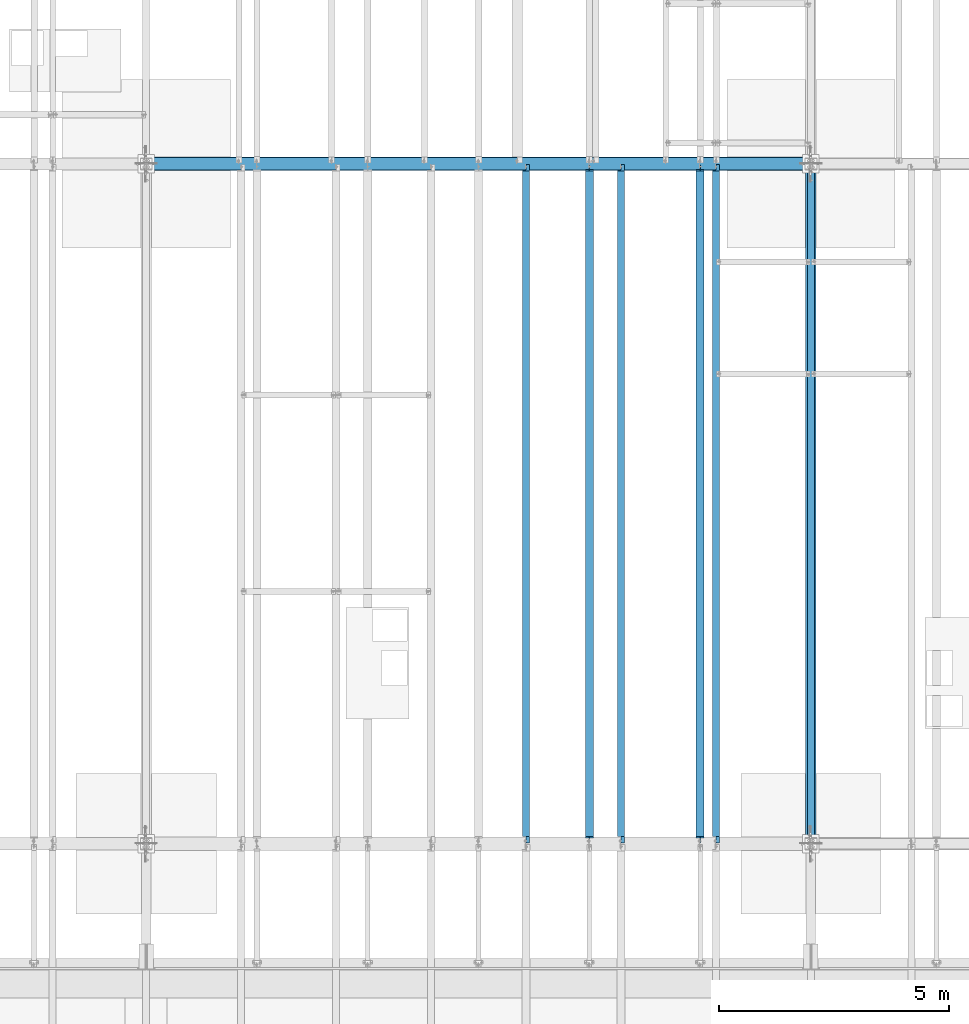
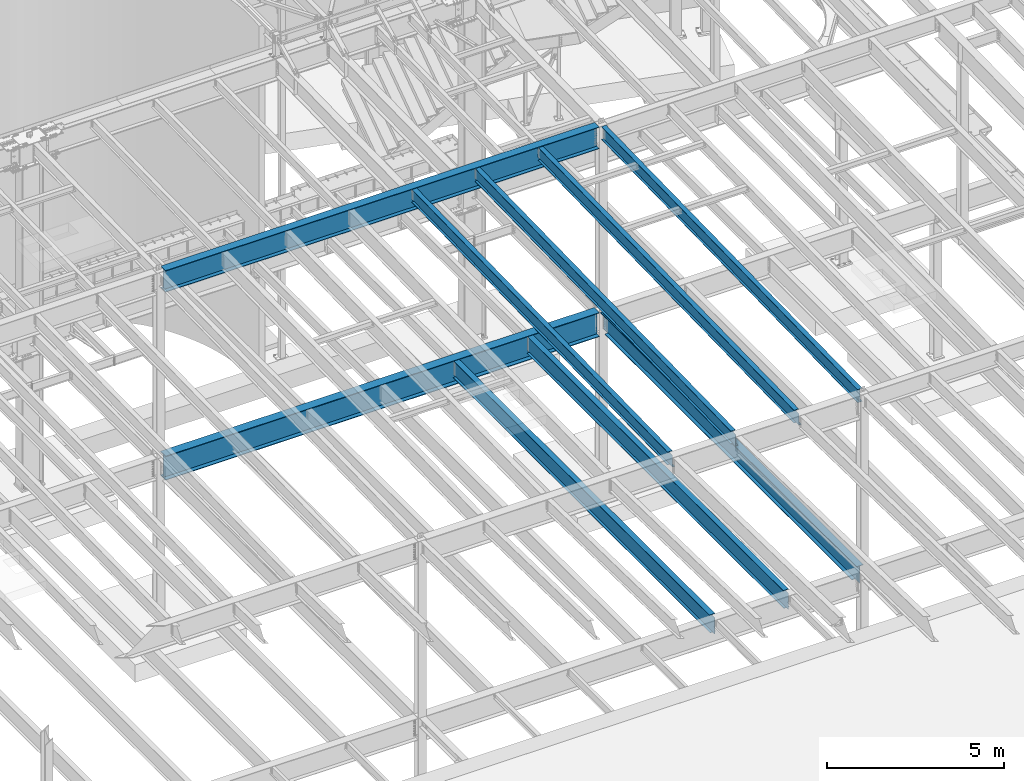
# One storey, part 1108 of 1763: 9 beams, 9 elements without a shape of their own.
"""IFC2X3 building model written with IfcOpenShell, lengths in millimetres."""

from ifc_helpers import new_model, si_unit, frame, origin_with_axes, place, context, subcontext, project, spatial, faceted_brep, material, type_object, element, aggregate, save


model = new_model("IFC2X3")

# Units and contexts
model_context = context("Model", 3, precision=1e-05, world=origin_with_axes())
body_context = subcontext(model_context, "Body", "Model", "MODEL_VIEW")
ifc_project = project(units=[si_unit("LENGTHUNIT", "METRE", prefix="MILLI"), si_unit("AREAUNIT", "SQUARE_METRE"), si_unit("VOLUMEUNIT", "CUBIC_METRE"), si_unit("MASSUNIT", "GRAM", prefix="KILO"), si_unit("TIMEUNIT", "SECOND"), si_unit("PLANEANGLEUNIT", "RADIAN"), si_unit("SOLIDANGLEUNIT", "STERADIAN"), si_unit("THERMODYNAMICTEMPERATUREUNIT", "DEGREE_CELSIUS"), si_unit("LUMINOUSINTENSITYUNIT", "LUMEN")], contexts=[model_context])

# Site, building, storey
site_placement = place(None, origin_with_axes())
site = spatial("IfcSite", under=ifc_project, at=site_placement, CompositionType="ELEMENT")
building_placement = place(site_placement, origin_with_axes())
building = spatial("IfcBuilding", under=site, at=building_placement, Name="Undefined", CompositionType="ELEMENT")
storey_placement = place(building_placement, origin_with_axes())
storey = spatial("IfcBuildingStorey", under=building, at=storey_placement, Name="Undefined", CompositionType="ELEMENT", Elevation=0.0)

# Assembly, beam
assembly_1_placement = place(storey_placement, origin_with_axes())
assembly_1 = element("IfcElementAssembly", 1, at=assembly_1_placement, inside=storey, Name="BEAM", AssemblyPlace="NOTDEFINED", PredefinedType="RIGID_FRAME")
ifc_material = material(Name="STEEL/A992")
beam_type_1 = type_object("IfcBeamType", Name="W18X35", PredefinedType="NOTDEFINED")
beam_1_placement = place(assembly_1_placement, frame((-37014.4944165555, 30027.4629676774, 11064.9232324289), z_axis=(0.0, -0.0206852279954837, 0.999786037781472), x_axis=(0.0, 0.999786037781472, 0.0206852279954825)))
beam_1 = element("IfcBeam", 2, at=beam_1_placement, type_object=beam_type_1, material=ifc_material, Name="BEAM", ObjectType="W18X35", context=body_context, shape_type="Brep", body=[
    faceted_brep([(161.234036217043, 4.26867060289806, -214.312499999869), (161.234036217025, 4.26882632687921, -225.424999999863), (10.5200655540102, 4.26881607816904, -225.424999999832), (10.7499793429743, 4.26866036980209, -214.312499999842), (161.234031325755, 76.1999999999971, -214.312499999867), (161.234031325748, 76.1999999999971, -225.424999999861), (161.234030986459, -3.96875, 187.065001487535), (161.234030986459, 3.96875, 187.065001487535), (160.267301063872, 3.96875, 182.204921969502), (160.267301063872, -3.96875, 182.204921969502), (157.514287163402, 3.96875, 178.084745501357), (157.514287163402, -3.96875, 178.084745501357), (153.394110695255, 3.96875, 175.331731600885), (153.394110695255, -3.96875, 175.331731600885), (148.534031177223, 3.96875, 174.365001678299), (148.534031177223, -3.96875, 174.365001678299), (18.7915826811914, 3.96875, 174.365001678325), (18.7915826811914, -3.96875, 174.365001678325), (10.7499793429743, -3.96875, -214.312499999842), (14757.8115434472, -3.96875, -214.312500002648), (14765.8531467846, -3.96875, 174.36500163611), (14641.5955948759, -3.96875, 174.365001636133), (14636.7355153579, -3.96875, 175.331731558719), (14632.6153388897, -3.96875, 178.084745459191), (14629.8623249892, -3.96875, 182.204921927336), (14628.8955950666, -3.96875, 187.065001445368), (14628.8955950666, -3.96875, 214.312499997053), (161.234030986467, -3.96875, 214.312499999809), (10.7499793429743, -76.1999999999971, -214.312499999842), (14757.8115434472, -76.1999999999971, -214.312500002648), (10.5200655540102, -76.1999999999971, -225.424999999832), (14757.5816296582, -76.1999999999971, -225.425000002639), (14641.5955921487, 4.26882640406257, -214.312500002627), (14641.5955921487, 4.26867068048159, -225.425000002617), (14641.5955830855, 76.1999999999971, -225.425000002617), (14641.5955830855, 76.1999999999971, -214.312500002628), (14757.8115434472, 4.26884104704368, -214.312500002648), (14757.5816296582, 4.26868529446074, -225.425000002639), (14757.8115434472, 3.96875, -214.312500002648), (14765.8531467846, 3.96875, 174.36500163611), (14641.5955948759, 3.96875, 174.365001636133), (14636.7355153579, 3.96875, 175.331731558719), (14632.6153388897, 3.96875, 178.084745459191), (14629.8623249892, 3.96875, 182.204921927336), (14628.8955950666, 3.96875, 187.065001445368), (14628.8955950666, -76.1999999999971, 225.424999997045), (14628.8955950666, -76.1999999999971, 214.312499997053), (14628.8955950666, 3.96875, 214.312499997053), (14628.8955950666, 76.1999999999971, 214.312499997053), (14628.8955950666, 76.1999999999971, 225.424999997045), (161.234030986467, 3.96875, 214.312499999809), (161.234030986467, 76.1999999999971, 214.312499999809), (161.23403098647, 76.1999999999971, 225.424999999799), (161.23403098647, -76.1999999999971, 225.424999999799), (161.234030986467, -76.1999999999971, 214.312499999809), (10.7499793429743, 3.96875, -214.312499999842)], [[[0, 1, 2, 3]], [[4, 5, 1, 0]], [[6, 7, 8, 9]], [[9, 8, 10, 11]], [[11, 10, 12, 13]], [[13, 12, 14, 15]], [[15, 14, 16, 17]], [[9, 11, 13, 15, 17, 18, 19, 20, 21, 22, 23, 24, 25, 26, 27, 6]], [[18, 28, 29, 19]], [[28, 30, 31, 29]], [[32, 33, 34, 35]], [[36, 37, 33, 32]], [[38, 39, 20, 19, 29, 31, 37, 36]], [[20, 39, 40, 21]], [[21, 40, 41, 22]], [[22, 41, 42, 23]], [[23, 42, 43, 24]], [[24, 43, 44, 25]], [[45, 46, 26, 25, 44, 47, 48, 49]], [[48, 47, 50, 51]], [[49, 48, 51, 52]], [[45, 49, 52, 53]], [[46, 45, 53, 54]], [[26, 46, 54, 27]], [[53, 52, 51, 50, 7, 6, 27, 54]], [[47, 44, 43, 42, 41, 40, 39, 38, 55, 16, 14, 12, 10, 8, 7, 50]], [[30, 28, 18, 17, 16, 55, 3, 2]], [[34, 33, 37, 31, 30, 2, 1, 5]], [[35, 34, 5, 4]], [[55, 38, 36, 32, 35, 4, 0, 3]]]),
])
aggregate(assembly_1, [beam_1])

assembly_2_placement = place(storey_placement, origin_with_axes())
assembly_2 = element("IfcElementAssembly", 3, at=assembly_2_placement, inside=storey, Name="BEAM", AssemblyPlace="NOTDEFINED", PredefinedType="RIGID_FRAME")
beam_2_placement = place(assembly_2_placement, frame((-34949.8372736984, 30027.4629676506, 11064.9232324289), z_axis=(0.0, -0.0206852279954837, 0.999786037781472), x_axis=(0.0, 0.999786037781472, 0.0206852279954825)))
beam_2 = element("IfcBeam", 4, at=beam_2_placement, type_object=beam_type_1, material=ifc_material, Name="BEAM", ObjectType="W18X35", context=body_context, shape_type="Brep", body=[
    faceted_brep([(135.16548513544, -76.1999999999971, -225.424999999856), (135.16548513544, 76.1999999999971, -225.424999999856), (14632.1422904328, 76.1999999999971, -225.425000002615), (14632.1422904328, -76.1999999999971, -225.425000002615), (135.395398924404, -76.1999999999971, -214.312499999864), (135.395398924404, -3.96875, -214.312499999864), (144.263502213013, -3.96875, 214.312499999811), (144.263502213013, -76.1999999999971, 214.312499999811), (144.493416001977, -76.1999999999971, 225.424999999803), (144.493416001977, 76.1999999999971, 225.424999999803), (144.263502213013, 76.1999999999971, 214.312499999811), (144.263502213013, 3.96875, 214.312499999811), (135.395398924404, 3.96875, -214.312499999864), (135.395398924404, 76.1999999999971, -214.312499999864), (14632.3722042217, -76.1999999999971, -214.312500002625), (14632.3722042217, -3.96875, -214.312500002625), (14641.2403075104, -3.96875, 214.312499997051), (14641.2403075104, -76.1999999999971, 214.312499997051), (14641.4702212993, -76.1999999999971, 225.424999997043), (14641.4702212993, 76.1999999999971, 225.424999997043), (14641.2403075104, 76.1999999999971, 214.312499997051), (14641.2403075104, 3.96875, 214.312499997051), (14632.3722042217, 3.96875, -214.312500002625), (14632.3722042217, 76.1999999999971, -214.312500002625)], [[[0, 1, 2, 3]], [[0, 4, 5, 6, 7, 8, 9, 10, 11, 12, 13, 1]], [[5, 4, 14, 15]], [[6, 5, 15, 16]], [[7, 6, 16, 17]], [[8, 7, 17, 18]], [[9, 8, 18, 19]], [[10, 9, 19, 20]], [[11, 10, 20, 21]], [[12, 11, 21, 22]], [[13, 12, 22, 23]], [[1, 13, 23, 2]], [[22, 21, 20, 19, 18, 17, 16, 15, 14, 3, 2, 23]], [[4, 0, 3, 14]]]),
])
aggregate(assembly_2, [beam_2])

assembly_3_placement = place(storey_placement, origin_with_axes())
assembly_3 = element("IfcElementAssembly", 5, at=assembly_3_placement, inside=storey, Name="BEAM", AssemblyPlace="NOTDEFINED", PredefinedType="RIGID_FRAME")
beam_3_placement = place(assembly_3_placement, frame((-39079.1515594127, 30027.4629676422, 11064.9232324289), z_axis=(0.0, -0.0206852279954837, 0.999786037781472), x_axis=(0.0, 0.999786037781472, 0.0206852279954825)))
beam_3 = element("IfcBeam", 6, at=beam_3_placement, type_object=beam_type_1, material=ifc_material, Name="BEAM", ObjectType="W18X35", context=body_context, shape_type="Brep", body=[
    faceted_brep([(161.234036217043, 4.26867060289806, -214.312499999869), (161.234036217025, 4.26882632687921, -225.424999999863), (10.5200655540102, 4.26881607816904, -225.424999999832), (10.7499793429743, 4.26866036980209, -214.312499999842), (161.234031325755, 76.1999999999971, -214.312499999867), (161.234031325748, 76.1999999999971, -225.424999999861), (161.234030986459, -3.96875, 187.065001487535), (161.234030986459, 3.96875, 187.065001487535), (160.267301063872, 3.96875, 182.204921969502), (160.267301063872, -3.96875, 182.204921969502), (157.514287163402, 3.96875, 178.084745501357), (157.514287163402, -3.96875, 178.084745501357), (153.394110695255, 3.96875, 175.331731600885), (153.394110695255, -3.96875, 175.331731600885), (148.534031177223, 3.96875, 174.365001678299), (148.534031177223, -3.96875, 174.365001678299), (18.7915826811914, 3.96875, 174.365001678325), (18.7915826811914, -3.96875, 174.365001678325), (10.7499793429743, -3.96875, -214.312499999842), (14757.8115434472, -3.96875, -214.312500002648), (14765.8531467846, -3.96875, 174.36500163611), (14641.5955948759, -3.96875, 174.365001636133), (14636.7355153579, -3.96875, 175.331731558719), (14632.6153388897, -3.96875, 178.084745459191), (14629.8623249892, -3.96875, 182.204921927336), (14628.8955950666, -3.96875, 187.065001445368), (14628.8955950666, -3.96875, 214.312499997053), (161.234030986467, -3.96875, 214.312499999809), (10.7499793429743, -76.1999999999971, -214.312499999842), (14757.8115434472, -76.1999999999971, -214.312500002648), (10.5200655540102, -76.1999999999971, -225.424999999832), (14757.5816296582, -76.1999999999971, -225.425000002639), (14641.5955921487, 4.26882640406257, -214.312500002627), (14641.5955921487, 4.26867068048159, -225.425000002617), (14641.5955830855, 76.1999999999971, -225.425000002617), (14641.5955830855, 76.1999999999971, -214.312500002628), (14757.8115434472, 4.26884104704368, -214.312500002648), (14757.5816296582, 4.26868529446074, -225.425000002639), (14757.8115434472, 3.96875, -214.312500002648), (14765.8531467846, 3.96875, 174.36500163611), (14641.5955948759, 3.96875, 174.365001636133), (14636.7355153579, 3.96875, 175.331731558719), (14632.6153388897, 3.96875, 178.084745459191), (14629.8623249892, 3.96875, 182.204921927336), (14628.8955950666, 3.96875, 187.065001445368), (14628.8955950666, -76.1999999999971, 225.424999997045), (14628.8955950666, -76.1999999999971, 214.312499997053), (14628.8955950666, 3.96875, 214.312499997053), (14628.8955950666, 76.1999999999971, 214.312499997053), (14628.8955950666, 76.1999999999971, 225.424999997045), (161.234030986467, 3.96875, 214.312499999809), (161.234030986467, 76.1999999999971, 214.312499999809), (161.23403098647, 76.1999999999971, 225.424999999799), (161.23403098647, -76.1999999999971, 225.424999999799), (161.234030986467, -76.1999999999971, 214.312499999809), (10.7499793429743, 3.96875, -214.312499999842)], [[[0, 1, 2, 3]], [[4, 5, 1, 0]], [[6, 7, 8, 9]], [[9, 8, 10, 11]], [[11, 10, 12, 13]], [[13, 12, 14, 15]], [[15, 14, 16, 17]], [[9, 11, 13, 15, 17, 18, 19, 20, 21, 22, 23, 24, 25, 26, 27, 6]], [[18, 28, 29, 19]], [[28, 30, 31, 29]], [[32, 33, 34, 35]], [[36, 37, 33, 32]], [[38, 39, 20, 19, 29, 31, 37, 36]], [[20, 39, 40, 21]], [[21, 40, 41, 22]], [[22, 41, 42, 23]], [[23, 42, 43, 24]], [[24, 43, 44, 25]], [[45, 46, 26, 25, 44, 47, 48, 49]], [[48, 47, 50, 51]], [[49, 48, 51, 52]], [[45, 49, 52, 53]], [[46, 45, 53, 54]], [[26, 46, 54, 27]], [[53, 52, 51, 50, 7, 6, 27, 54]], [[47, 44, 43, 42, 41, 40, 39, 38, 55, 16, 14, 12, 10, 8, 7, 50]], [[30, 28, 18, 17, 16, 55, 3, 2]], [[34, 33, 37, 31, 30, 2, 1, 5]], [[35, 34, 5, 4]], [[55, 38, 36, 32, 35, 4, 0, 3]]]),
])
aggregate(assembly_3, [beam_3])

assembly_4_placement = place(storey_placement, origin_with_axes())
assembly_4 = element("IfcElementAssembly", 7, at=assembly_4_placement, inside=storey, Name="BEAM", AssemblyPlace="NOTDEFINED", PredefinedType="RIGID_FRAME")
beam_4_placement = place(assembly_4_placement, frame((-41143.8087022698, 30027.4629676774, 11064.9232324289), z_axis=(0.0, -0.0206852279954837, 0.999786037781472), x_axis=(0.0, 0.999786037781472, 0.0206852279954825)))
beam_4 = element("IfcBeam", 8, at=beam_4_placement, type_object=beam_type_1, material=ifc_material, Name="BEAM", ObjectType="W18X35", context=body_context, shape_type="Brep", body=[
    faceted_brep([(161.234036217043, 4.26867060289806, -214.312499999869), (161.234036217025, 4.26882632687921, -225.424999999863), (10.5200655540102, 4.26881607816904, -225.424999999832), (10.7499793429743, 4.26866036980209, -214.312499999842), (161.234031325755, 76.1999999999971, -214.312499999867), (161.234031325748, 76.1999999999971, -225.424999999861), (161.234030986459, -3.96875, 187.065001487535), (161.234030986459, 3.96875, 187.065001487535), (160.267301063872, 3.96875, 182.204921969502), (160.267301063872, -3.96875, 182.204921969502), (157.514287163402, 3.96875, 178.084745501357), (157.514287163402, -3.96875, 178.084745501357), (153.394110695255, 3.96875, 175.331731600885), (153.394110695255, -3.96875, 175.331731600885), (148.534031177223, 3.96875, 174.365001678299), (148.534031177223, -3.96875, 174.365001678299), (18.7915826811914, 3.96875, 174.365001678325), (18.7915826811914, -3.96875, 174.365001678325), (10.7499793429743, -3.96875, -214.312499999842), (14757.8115434472, -3.96875, -214.312500002648), (14765.8531467846, -3.96875, 174.36500163611), (14641.5955948759, -3.96875, 174.365001636133), (14636.7355153579, -3.96875, 175.331731558719), (14632.6153388897, -3.96875, 178.084745459191), (14629.8623249892, -3.96875, 182.204921927336), (14628.8955950666, -3.96875, 187.065001445368), (14628.8955950666, -3.96875, 214.312499997053), (161.234030986467, -3.96875, 214.312499999809), (10.7499793429743, -76.1999999999971, -214.312499999842), (14757.8115434472, -76.1999999999971, -214.312500002648), (10.5200655540102, -76.1999999999971, -225.424999999832), (14757.5816296582, -76.1999999999971, -225.425000002639), (14641.5955921487, 4.26882640406257, -214.312500002627), (14641.5955921487, 4.26867068048159, -225.425000002617), (14641.5955830855, 76.1999999999971, -225.425000002617), (14641.5955830855, 76.1999999999971, -214.312500002628), (14757.8115434472, 4.26884104704368, -214.312500002648), (14757.5816296582, 4.26868529446074, -225.425000002639), (14757.8115434472, 3.96875, -214.312500002648), (14765.8531467846, 3.96875, 174.36500163611), (14641.5955948759, 3.96875, 174.365001636133), (14636.7355153579, 3.96875, 175.331731558719), (14632.6153388897, 3.96875, 178.084745459191), (14629.8623249892, 3.96875, 182.204921927336), (14628.8955950666, 3.96875, 187.065001445368), (14628.8955950666, -76.1999999999971, 225.424999997045), (14628.8955950666, -76.1999999999971, 214.312499997053), (14628.8955950666, 3.96875, 214.312499997053), (14628.8955950666, 76.1999999999971, 214.312499997053), (14628.8955950666, 76.1999999999971, 225.424999997045), (161.234030986467, 3.96875, 214.312499999809), (161.234030986467, 76.1999999999971, 214.312499999809), (161.23403098647, 76.1999999999971, 225.424999999799), (161.23403098647, -76.1999999999971, 225.424999999799), (161.234030986467, -76.1999999999971, 214.312499999809), (10.7499793429743, 3.96875, -214.312499999842)], [[[0, 1, 2, 3]], [[4, 5, 1, 0]], [[6, 7, 8, 9]], [[9, 8, 10, 11]], [[11, 10, 12, 13]], [[13, 12, 14, 15]], [[15, 14, 16, 17]], [[9, 11, 13, 15, 17, 18, 19, 20, 21, 22, 23, 24, 25, 26, 27, 6]], [[18, 28, 29, 19]], [[28, 30, 31, 29]], [[32, 33, 34, 35]], [[36, 37, 33, 32]], [[38, 39, 20, 19, 29, 31, 37, 36]], [[20, 39, 40, 21]], [[21, 40, 41, 22]], [[22, 41, 42, 23]], [[23, 42, 43, 24]], [[24, 43, 44, 25]], [[45, 46, 26, 25, 44, 47, 48, 49]], [[48, 47, 50, 51]], [[49, 48, 51, 52]], [[45, 49, 52, 53]], [[46, 45, 53, 54]], [[26, 46, 54, 27]], [[53, 52, 51, 50, 7, 6, 27, 54]], [[47, 44, 43, 42, 41, 40, 39, 38, 55, 16, 14, 12, 10, 8, 7, 50]], [[30, 28, 18, 17, 16, 55, 3, 2]], [[34, 33, 37, 31, 30, 2, 1, 5]], [[35, 34, 5, 4]], [[55, 38, 36, 32, 35, 4, 0, 3]]]),
])
aggregate(assembly_4, [beam_4])

assembly_5_placement = place(storey_placement, origin_with_axes())
assembly_5 = element("IfcElementAssembly", 9, at=assembly_5_placement, inside=storey, Name="BEAM", AssemblyPlace="NOTDEFINED", PredefinedType="RIGID_FRAME")
beam_type_2 = type_object("IfcBeamType", Name="W24X55", PredefinedType="NOTDEFINED")
beam_5_placement = place(assembly_5_placement, frame((-37358.603940365, 30022.8, 4894.2625), z_axis=(0.0, 0.0, 1.0), x_axis=(0.0, 1.0, 0.0)))
beam_5 = element("IfcBeam", 10, at=beam_5_placement, type_object=beam_type_2, material=ifc_material, Name="BEAM", ObjectType="W24X55", context=body_context, shape_type="Brep", body=[
    faceted_brep([(19.8437500000036, -5.06263076800678, -287.3375), (19.8437500000036, -5.06239138569799, -300.0375), (121.443760724065, -5.06237878766842, -300.0375), (121.443760724113, -5.06261816997721, -287.3375), (121.443815955325, -88.9000000000015, -287.3375), (121.443815955325, -88.9000000000015, -300.0375), (159.543750000004, -4.76249999999709, 280.727501487732), (159.543750000004, 4.76249999999709, 280.727501487732), (158.577020077417, 4.76249999999709, 275.867421969687), (158.577020077417, -4.76249999999709, 275.867421969687), (155.824006176939, 4.76249999999709, 271.747245501533), (155.824006176939, -4.76249999999709, 271.747245501533), (151.703829708786, 4.76249999999709, 268.994231601055), (151.703829708786, -4.76249999999709, 268.994231601055), (146.843750190739, 4.76249999999709, 268.027501678467), (146.843750190739, -4.76249999999709, 268.027501678467), (19.8437500000036, 4.76249999999709, 268.027501678467), (19.8437500000036, -4.76249999999709, 268.027501678467), (19.84375, -4.76249999999709, -287.3375), (14762.95625, -4.76249999999709, -287.3375), (14762.95625, -4.76249999999709, 268.027501678467), (14635.9562498093, -4.76249999999709, 268.027501678467), (14631.0961702912, -4.76249999999709, 268.994231601055), (14626.9759938231, -4.76249999999709, 271.747245501533), (14624.2229799226, -4.76249999999709, 275.867421969687), (14623.25625, -4.76249999999709, 280.727501487732), (14623.25625, -4.76249999999709, 287.3375), (159.543750000004, -4.76249999999709, 287.3375), (14762.95625, 4.76249999999709, 268.027501678467), (14635.9562498093, 4.76249999999709, 268.027501678467), (14631.0961702912, 4.76249999999709, 268.994231601055), (14626.9759938231, 4.76249999999709, 271.747245501533), (14624.2229799226, 4.76249999999709, 275.867421969687), (14623.25625, 4.76249999999709, 280.727501487732), (14623.25625, -88.8999999999942, 300.0375), (14623.25625, -88.8999999999942, 287.3375), (14623.25625, 4.76249999999709, 287.3375), (14623.25625, 88.8999999999942, 287.3375), (14623.25625, 88.8999999999942, 300.0375), (159.543750000004, 4.76249999999709, 287.3375), (159.543750000004, 88.8999999999942, 287.3375), (159.543750000004, 88.8999999999942, 300.0375), (159.543750000004, -88.8999999999942, 300.0375), (159.543750000004, -88.8999999999942, 287.3375), (14762.95625, 4.76249999999709, -287.3375), (19.84375, 4.76249999999709, -287.3375), (14762.95625, 5.0626307680941, -287.3375), (14661.3562392746, 5.06261817002087, -287.3375), (14661.356228879, 88.8999999999942, -287.3375), (121.443751839222, 88.9000000000015, -287.3375), (121.443761016704, 5.06237876559317, -287.3375), (19.8437500000036, 5.06236616715614, -287.3375), (121.443761016661, 5.06261814791651, -300.0375), (19.8437500000036, 5.06260554946493, -300.0375), (121.443751839222, 88.9000000000015, -300.0375), (14661.356228879, 88.8999999999942, -300.0375), (14661.3562392746, 5.06237878771208, -300.0375), (14762.95625, 5.0623913857853, -300.0375), (14762.95625, -5.06236616667593, -287.3375), (14762.95625, -5.06260554897017, -300.0375), (14661.3562389844, -5.0623787647346, -287.3375), (14661.3562389844, -5.06261814705795, -300.0375), (14661.3562493798, -88.8999999999942, -287.3375), (14661.3562493798, -88.8999999999942, -300.0375)], [[[0, 1, 2, 3]], [[4, 3, 2, 5]], [[6, 7, 8, 9]], [[9, 8, 10, 11]], [[11, 10, 12, 13]], [[13, 12, 14, 15]], [[15, 14, 16, 17]], [[9, 11, 13, 15, 17, 18, 19, 20, 21, 22, 23, 24, 25, 26, 27, 6]], [[20, 28, 29, 21]], [[21, 29, 30, 22]], [[22, 30, 31, 23]], [[23, 31, 32, 24]], [[24, 32, 33, 25]], [[34, 35, 26, 25, 33, 36, 37, 38]], [[37, 36, 39, 40]], [[38, 37, 40, 41]], [[34, 38, 41, 42]], [[35, 34, 42, 43]], [[26, 35, 43, 27]], [[42, 41, 40, 39, 7, 6, 27, 43]], [[36, 33, 32, 31, 30, 29, 28, 44, 45, 16, 14, 12, 10, 8, 7, 39]], [[45, 44, 46, 47, 48, 49, 50, 51]], [[50, 52, 53, 51]], [[49, 54, 52, 50]], [[48, 55, 54, 49]], [[47, 56, 55, 48]], [[46, 57, 56, 47]], [[44, 28, 20, 19, 58, 59, 57, 46]], [[58, 60, 61, 59]], [[62, 63, 61, 60]], [[63, 62, 4, 5]], [[1, 53, 52, 54, 55, 56, 57, 59, 61, 63, 5, 2]], [[18, 17, 16, 45, 51, 53, 1, 0]], [[62, 60, 58, 19, 18, 0, 3, 4]]]),
])
aggregate(assembly_5, [beam_5])

assembly_6_placement = place(storey_placement, origin_with_axes())
assembly_6 = element("IfcElementAssembly", 11, at=assembly_6_placement, inside=storey, Name="BEAM", AssemblyPlace="NOTDEFINED", PredefinedType="RIGID_FRAME")
beam_6_placement = place(assembly_6_placement, frame((-39767.3706070317, 30022.8, 4894.2625), z_axis=(0.0, 0.0, 1.0), x_axis=(0.0, 1.0, 0.0)))
beam_6 = element("IfcBeam", 12, at=beam_6_placement, type_object=beam_type_2, material=ifc_material, Name="BEAM", ObjectType="W24X55", context=body_context, shape_type="Brep", body=[
    faceted_brep([(19.8437500000036, -5.06263076800678, -287.3375), (19.8437500000036, -5.06239138569799, -300.0375), (121.443760724065, -5.06237878766842, -300.0375), (121.443760724113, -5.06261816997721, -287.3375), (121.443815955325, -88.9000000000015, -287.3375), (121.443815955325, -88.9000000000015, -300.0375), (159.543750000004, -4.76249999999709, 280.727501487732), (159.543750000004, 4.76249999999709, 280.727501487732), (158.577020077417, 4.76249999999709, 275.867421969687), (158.577020077417, -4.76249999999709, 275.867421969687), (155.824006176939, 4.76249999999709, 271.747245501533), (155.824006176939, -4.76249999999709, 271.747245501533), (151.703829708786, 4.76249999999709, 268.994231601055), (151.703829708786, -4.76249999999709, 268.994231601055), (146.843750190739, 4.76249999999709, 268.027501678467), (146.843750190739, -4.76249999999709, 268.027501678467), (19.8437500000036, 4.76249999999709, 268.027501678467), (19.8437500000036, -4.76249999999709, 268.027501678467), (19.84375, -4.76249999999709, -287.3375), (14762.95625, -4.76249999999709, -287.3375), (14762.95625, -4.76249999999709, 268.027501678467), (14635.9562498093, -4.76249999999709, 268.027501678467), (14631.0961702912, -4.76249999999709, 268.994231601055), (14626.9759938231, -4.76249999999709, 271.747245501533), (14624.2229799226, -4.76249999999709, 275.867421969687), (14623.25625, -4.76249999999709, 280.727501487732), (14623.25625, -4.76249999999709, 287.3375), (159.543750000004, -4.76249999999709, 287.3375), (14762.95625, 4.76249999999709, 268.027501678467), (14635.9562498093, 4.76249999999709, 268.027501678467), (14631.0961702912, 4.76249999999709, 268.994231601055), (14626.9759938231, 4.76249999999709, 271.747245501533), (14624.2229799226, 4.76249999999709, 275.867421969687), (14623.25625, 4.76249999999709, 280.727501487732), (14623.25625, -88.8999999999942, 300.0375), (14623.25625, -88.8999999999942, 287.3375), (14623.25625, 4.76249999999709, 287.3375), (14623.25625, 88.8999999999942, 287.3375), (14623.25625, 88.8999999999942, 300.0375), (159.543750000004, 4.76249999999709, 287.3375), (159.543750000004, 88.8999999999942, 287.3375), (159.543750000004, 88.8999999999942, 300.0375), (159.543750000004, -88.8999999999942, 300.0375), (159.543750000004, -88.8999999999942, 287.3375), (14762.95625, 4.76249999999709, -287.3375), (19.84375, 4.76249999999709, -287.3375), (14762.95625, 5.0626307680941, -287.3375), (14661.3562392746, 5.06261817002087, -287.3375), (14661.356228879, 88.8999999999942, -287.3375), (121.443751839222, 88.9000000000015, -287.3375), (121.443761016704, 5.06237876559317, -287.3375), (19.8437500000036, 5.06236616715614, -287.3375), (121.443761016661, 5.06261814791651, -300.0375), (19.8437500000036, 5.06260554946493, -300.0375), (121.443751839222, 88.9000000000015, -300.0375), (14661.356228879, 88.8999999999942, -300.0375), (14661.3562392746, 5.06237878771208, -300.0375), (14762.95625, 5.0623913857853, -300.0375), (14762.95625, -5.06236616667593, -287.3375), (14762.95625, -5.06260554897017, -300.0375), (14661.3562389844, -5.0623787647346, -287.3375), (14661.3562389844, -5.06261814705795, -300.0375), (14661.3562493798, -88.8999999999942, -287.3375), (14661.3562493798, -88.8999999999942, -300.0375)], [[[0, 1, 2, 3]], [[4, 3, 2, 5]], [[6, 7, 8, 9]], [[9, 8, 10, 11]], [[11, 10, 12, 13]], [[13, 12, 14, 15]], [[15, 14, 16, 17]], [[9, 11, 13, 15, 17, 18, 19, 20, 21, 22, 23, 24, 25, 26, 27, 6]], [[20, 28, 29, 21]], [[21, 29, 30, 22]], [[22, 30, 31, 23]], [[23, 31, 32, 24]], [[24, 32, 33, 25]], [[34, 35, 26, 25, 33, 36, 37, 38]], [[37, 36, 39, 40]], [[38, 37, 40, 41]], [[34, 38, 41, 42]], [[35, 34, 42, 43]], [[26, 35, 43, 27]], [[42, 41, 40, 39, 7, 6, 27, 43]], [[36, 33, 32, 31, 30, 29, 28, 44, 45, 16, 14, 12, 10, 8, 7, 39]], [[45, 44, 46, 47, 48, 49, 50, 51]], [[50, 52, 53, 51]], [[49, 54, 52, 50]], [[48, 55, 54, 49]], [[47, 56, 55, 48]], [[46, 57, 56, 47]], [[44, 28, 20, 19, 58, 59, 57, 46]], [[58, 60, 61, 59]], [[62, 63, 61, 60]], [[63, 62, 4, 5]], [[1, 53, 52, 54, 55, 56, 57, 59, 61, 63, 5, 2]], [[18, 17, 16, 45, 51, 53, 1, 0]], [[62, 60, 58, 19, 18, 0, 3, 4]]]),
])
aggregate(assembly_6, [beam_6])

assembly_7_placement = place(storey_placement, origin_with_axes())
assembly_7 = element("IfcElementAssembly", 13, at=assembly_7_placement, inside=storey, Name="BEAM", AssemblyPlace="NOTDEFINED", PredefinedType="RIGID_FRAME")
beam_type_3 = type_object("IfcBeamType", Name="W33X118", PredefinedType="NOTDEFINED")
beam_7_placement = place(assembly_7_placement, frame((-49402.4372736983, 44805.6, 4776.7875), z_axis=(0.0, 0.0, 1.0), x_axis=(1.0, 0.0, 0.0)))
beam_7 = element("IfcBeam", 14, at=beam_7_placement, type_object=beam_type_3, material=ifc_material, Name="BEAM", ObjectType="W33X118", context=body_context, shape_type="Brep", body=[
    faceted_brep([(141.287499999999, 146.049999999999, -417.512500000001), (141.287499999999, 146.049999999999, -398.4625), (14311.3125, 146.049999999999, -398.4625), (14311.3125, 146.049999999999, -417.512500000001), (141.287499999999, 7.14374999999927, -398.4625), (14311.3125, 7.14374999999927, -398.4625), (141.287499999999, 7.14374999999927, 398.4625), (14311.3125, 7.14374999999927, 398.4625), (141.287499999999, 146.049999999999, 398.4625), (14311.3125, 146.049999999999, 398.4625), (141.287499999999, 146.049999999999, 417.512500000001), (14311.3125, 146.049999999999, 417.512500000001), (141.287499999999, -146.049999999999, 417.512500000001), (14311.3125, -146.049999999999, 417.512500000001), (141.287499999999, -146.049999999999, 398.4625), (14311.3125, -146.049999999999, 398.4625), (141.287499999999, -7.14374999999927, 398.4625), (14311.3125, -7.14374999999927, 398.4625), (141.287499999999, -7.14374999999927, -398.4625), (14311.3125, -7.14374999999927, -398.4625), (141.287499999999, -146.049999999999, -398.4625), (14311.3125, -146.049999999999, -398.4625), (141.287499999999, -146.049999999999, -417.512500000001), (14311.3125, -146.049999999999, -417.512500000001)], [[[0, 1, 2, 3]], [[1, 4, 5, 2]], [[4, 6, 7, 5]], [[6, 8, 9, 7]], [[8, 10, 11, 9]], [[10, 12, 13, 11]], [[12, 14, 15, 13]], [[14, 16, 17, 15]], [[16, 18, 19, 17]], [[18, 20, 21, 19]], [[20, 22, 23, 21]], [[22, 0, 3, 23]], [[5, 7, 9, 11, 13, 15, 17, 19, 21, 23, 3, 2]], [[22, 20, 18, 16, 14, 12, 10, 8, 6, 4, 1, 0]]]),
])
aggregate(assembly_7, [beam_7])

assembly_8_placement = place(storey_placement, origin_with_axes())
assembly_8 = element("IfcElementAssembly", 15, at=assembly_8_placement, inside=storey, Name="BEAM", AssemblyPlace="NOTDEFINED", PredefinedType="RIGID_FRAME")
beam_type_4 = type_object("IfcBeamType", Name="W30X99", PredefinedType="NOTDEFINED")
beam_8_placement = place(assembly_8_placement, frame((-49402.4372736983, 44805.5999999732, 11218.9213409688), z_axis=(0.0, 0.0, 1.0), x_axis=(1.0, 0.0, 0.0)))
beam_8 = element("IfcBeam", 16, at=beam_8_placement, type_object=beam_type_4, material=ifc_material, Name="BEAM", ObjectType="W30X99", context=body_context, shape_type="Brep", body=[
    faceted_brep([(141.287499999999, 133.349999999999, -376.237499999999), (141.287499999999, 133.349999999999, -358.775), (14311.3125, 133.349999999999, -358.775), (14311.3125, 133.349999999999, -376.237499999999), (141.287500000006, 6.34999999999854, -358.775), (14311.3125, 6.34999999999854, -358.775), (141.287500000006, 6.34999999999854, 358.775), (14311.3125, 6.34999999999854, 358.775), (141.287499999999, 133.349999999999, 358.775), (14311.3125, 133.349999999999, 358.775), (141.287499999999, 133.349999999999, 376.237499999999), (14311.3125, 133.349999999999, 376.237499999999), (141.287499999999, -133.349999999999, 376.237499999999), (14311.3125, -133.349999999999, 376.237499999999), (141.287499999999, -133.349999999999, 358.775), (14311.3125, -133.349999999999, 358.775), (141.287500000006, -6.34999999999854, 358.775), (14311.3125, -6.34999999999854, 358.775), (141.287500000006, -6.34999999999854, -358.775), (14311.3125, -6.34999999999854, -358.775), (141.287499999999, -133.349999999999, -358.775), (14311.3125, -133.349999999999, -358.775), (141.287499999999, -133.349999999999, -376.237499999999), (14311.3125, -133.349999999999, -376.237499999999)], [[[0, 1, 2, 3]], [[1, 4, 5, 2]], [[4, 6, 7, 5]], [[6, 8, 9, 7]], [[8, 10, 11, 9]], [[10, 12, 13, 11]], [[12, 14, 15, 13]], [[14, 16, 17, 15]], [[16, 18, 19, 17]], [[18, 20, 21, 19]], [[20, 22, 23, 21]], [[22, 0, 3, 23]], [[5, 7, 9, 11, 13, 15, 17, 19, 21, 23, 3, 2]], [[22, 20, 18, 16, 14, 12, 10, 8, 6, 4, 1, 0]]]),
])
aggregate(assembly_8, [beam_8])

assembly_9_placement = place(storey_placement, origin_with_axes())
assembly_9 = element("IfcElementAssembly", 17, at=assembly_9_placement, inside=storey, Name="BEAM", AssemblyPlace="NOTDEFINED", PredefinedType="RIGID_FRAME")
beam_type_5 = type_object("IfcBeamType", Name="W24X84", PredefinedType="NOTDEFINED")
beam_9_placement = place(assembly_9_placement, frame((-34949.8372736984, 30022.8, 4887.9125), z_axis=(0.0, 0.0, 1.0), x_axis=(0.0, 1.0, 0.0)))
beam_9 = element("IfcBeam", 18, at=beam_9_placement, type_object=beam_type_5, material=ifc_material, Name="BEAM", ObjectType="W24X84", context=body_context, shape_type="Brep", body=[
    faceted_brep([(144.462500000001, -6.65027077648119, -287.3375), (144.462500000001, -6.64991989452392, -306.3875), (398.462548051273, -6.64982312094799, -306.3875), (398.462548051411, -6.65017400289071, -287.3375), (398.462589065799, -114.300000000003, -287.3375), (398.462589065799, -114.300000000003, -306.3875), (144.462500000001, -6.34999999999854, 287.3375), (144.462500000001, -6.34999999999854, -287.3375), (14638.3375, -6.34999999999854, -287.3375), (14638.3375, -6.34999999999854, 287.3375), (144.462500000001, -114.300000000003, 287.3375), (14638.3375, -114.300000000003, 287.3375), (144.462500000001, -114.300000000003, 306.3875), (14638.3375, -114.300000000003, 306.3875), (144.462500000001, 114.300000000003, 306.3875), (14638.3375, 114.300000000003, 306.3875), (144.462500000001, 114.300000000003, 287.3375), (14638.3375, 114.300000000003, 287.3375), (144.462500000001, 6.34999999999854, 287.3375), (14638.3375, 6.34999999999854, 287.3375), (144.462500000001, 6.34999999999854, -287.3375), (14638.3375, 6.34999999999854, -287.3375), (14638.3375, 6.65027077697596, -287.3375), (14384.3374519492, 6.65017400338547, -287.3375), (14384.3374109348, 114.300000000003, -287.3375), (398.462501906062, 114.300000000003, -287.3375), (398.462542919809, 6.64982301944838, -287.3375), (144.462500000001, 6.64972624585062, -287.3375), (398.462542919671, 6.65017390138382, -306.3875), (144.462500000001, 6.65007712780789, -306.3875), (398.462501906062, 114.300000000003, -306.3875), (14384.3374109348, 114.300000000003, -306.3875), (14384.3374519493, 6.64982312144275, -306.3875), (14638.3375, 6.64991989501868, -306.3875), (14638.3375, -6.64972624439542, -287.3375), (14638.3375, -6.6500771263527, -306.3875), (14384.337457085, -6.64982301799319, -287.3375), (14384.3374570851, -6.65017389992863, -306.3875), (14384.3374980991, -114.300000000003, -287.3375), (14384.3374980991, -114.300000000003, -306.3875)], [[[0, 1, 2, 3]], [[4, 3, 2, 5]], [[6, 7, 8, 9]], [[10, 6, 9, 11]], [[12, 10, 11, 13]], [[14, 12, 13, 15]], [[16, 14, 15, 17]], [[18, 16, 17, 19]], [[20, 18, 19, 21]], [[20, 21, 22, 23, 24, 25, 26, 27]], [[26, 28, 29, 27]], [[25, 30, 28, 26]], [[24, 31, 30, 25]], [[23, 32, 31, 24]], [[22, 33, 32, 23]], [[21, 19, 17, 15, 13, 11, 9, 8, 34, 35, 33, 22]], [[34, 36, 37, 35]], [[38, 39, 37, 36]], [[39, 38, 4, 5]], [[1, 29, 28, 30, 31, 32, 33, 35, 37, 39, 5, 2]], [[7, 6, 10, 12, 14, 16, 18, 20, 27, 29, 1, 0]], [[38, 36, 34, 8, 7, 0, 3, 4]]]),
])
aggregate(assembly_9, [beam_9])

save(model, "model.ifc")
